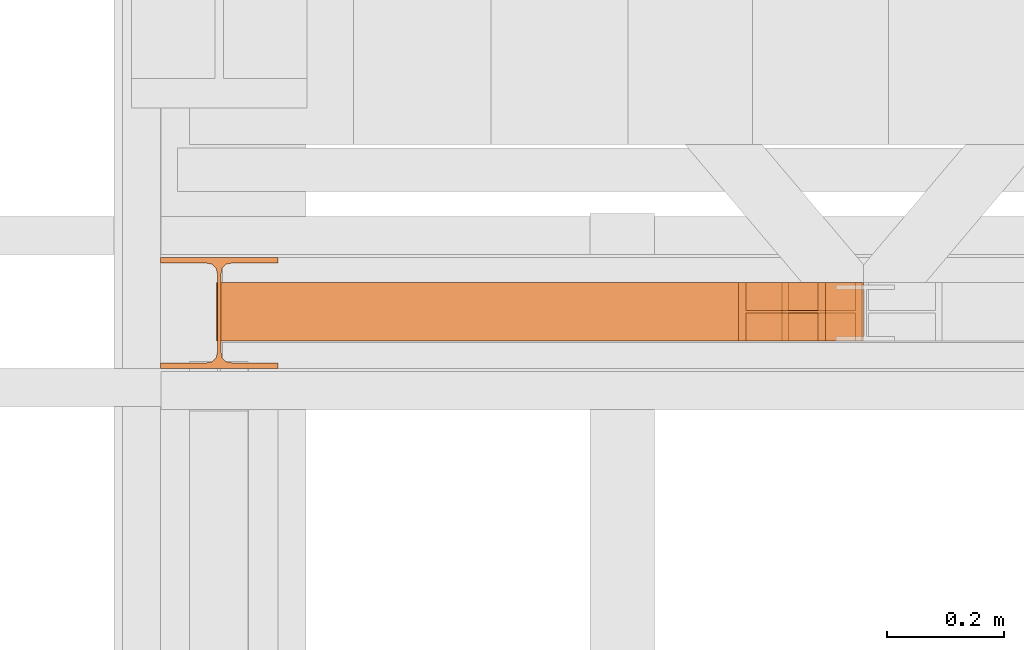
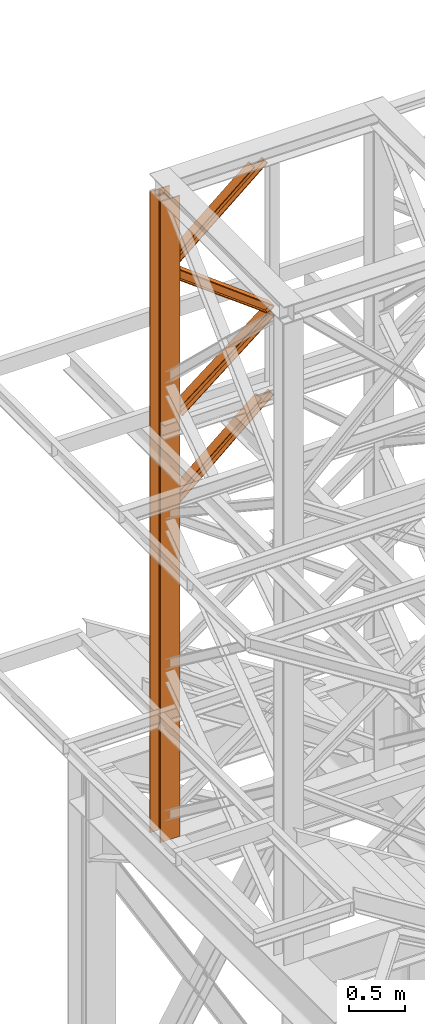
# One storey, part 97 of 208: 5 proxies.
"""IFC2X3 building model written with IfcOpenShell, lengths in millimetres."""

from ifc_helpers import new_model, entity, si_unit, converted_unit, frame, origin, origin_with_axes, place, context, subcontext, project, spatial, faceted_brep, element, save


model = new_model("IFC2X3")

# Units and contexts
model_context = context("Model", 3, precision=1e-05, world=origin())
plan_context = context("Plan", 3, precision=1e-05, world=origin())
body_context = subcontext(model_context, "Body", "Model", "MODEL_VIEW")
ifc_project = project(units=[si_unit("LENGTHUNIT", "METRE", prefix="MILLI"), converted_unit("PLANEANGLEUNIT", "DEGREE", entity("IfcPlaneAngleMeasure", 0.0174532925199433), si_unit("PLANEANGLEUNIT", "RADIAN"), dimensions=[0, 0, 0, 0, 0, 0, 0]), si_unit("AREAUNIT", "SQUARE_METRE"), si_unit("VOLUMEUNIT", "CUBIC_METRE")], contexts=[model_context, plan_context])

# Building, storey
building_placement = place(None, origin())
building = spatial("IfcBuilding", under=ifc_project, at=building_placement, CompositionType="COMPLEX")
storey_placement = place(building_placement, origin_with_axes())
storey = spatial("IfcBuildingStorey", under=building, at=storey_placement, Name="Geschoss", CompositionType="ELEMENT")

# Proxies
proxy_1_placement = place(storey_placement, frame((-3406.745032961453, -13857.57439657637, 5284.990005364415), z_axis=(0.0, 0.0, 1.0), x_axis=(1.0, 0.0, 0.0)))
element("IfcBuildingElementProxy", 1, at=proxy_1_placement, inside=storey, context=body_context, shape_type="Brep", body=[
    faceted_brep([(0.01000000000021828, 190.0100125169756, 6965.010053329393), (200.0100029802325, 190.0100125169756, 6965.010053329393), (200.0100029802325, 180.0100146031382, 6965.010053329393), (121.2600035762789, 180.0100071525576, 6965.010053329393), (111.9441915473344, 178.1454621052744, 6965.010053329393), (105.1245498640838, 171.3258190250399, 6965.010053329393), (103.2600015571716, 162.010007927418, 6965.010053329393), (103.2600015571716, 28.00999713897727, 6965.010053329393), (105.1245498640838, 18.69418604135535, 6965.010053329393), (111.9441915473344, 11.87454296112082, 6965.010053329393), (121.2600035762789, 10.00999791383765, 6965.010053329393), (200.0100029802325, 10.00999791383765, 6965.010053329393), (200.0100029802325, 0.01000000000021828, 6965.010053329393), (0.01000000000021828, 0.01000000000021828, 6965.010053329393), (0.01000000000021828, 10.00999791383765, 6965.010053329393), (78.75999940395377, 10.00999791383765, 6965.010053329393), (88.07581143289826, 11.87454296112082, 6965.010053329393), (94.89545311614893, 18.69418604135535, 6965.010053329393), (96.76000142306111, 28.00999713897727, 6965.010053329393), (96.76000142306111, 162.010007927418, 6965.010053329393), (94.89545311614893, 171.3258190250399, 6965.010053329393), (88.07581143289826, 178.1454621052744, 6965.010053329393), (78.75999940395377, 180.0100071525576, 6965.010053329393), (0.01000000000021828, 180.0100146031382, 6965.010053329393), (200.0100029802325, 190.0100125169756, 6965.010053329393), (0.01000000000021828, 190.0100125169756, 6965.010053329393), (0.01000000000203727, 190.0100125169756, 0.01000000000112777), (200.0100029802343, 190.0100125169756, 0.01000000000112777), (200.0100029802325, 180.0100146031382, 6965.010053329393), (200.0100029802325, 190.0100125169756, 6965.010053329393), (200.0100029802343, 190.0100125169756, 0.01000000000112777), (200.0100029802343, 180.0100146031382, 0.01000000000112777), (121.2600035762789, 180.0100071525576, 6965.010053329393), (200.0100029802325, 180.0100146031382, 6965.010053329393), (200.0100029802343, 180.0100146031382, 0.01000000000112777), (121.2600035762807, 180.0100071525576, 0.01000000000112777), (111.9441915473344, 178.1454621052744, 6965.010053329393), (121.2600035762789, 180.0100071525576, 6965.010053329393), (121.2600035762807, 180.0100071525576, 0.01000000000112777), (111.9441915473362, 178.1454621052744, 0.01000000000112777), (105.1245498640838, 171.3258190250399, 6965.010053329393), (111.9441915473344, 178.1454621052744, 6965.010053329393), (111.9441915473362, 178.1454621052744, 0.01000000000112777), (105.1245498640856, 171.3258190250399, 0.01000000000112777), (103.2600015571716, 162.010007927418, 6965.010053329393), (105.1245498640838, 171.3258190250399, 6965.010053329393), (105.1245498640856, 171.3258190250399, 0.01000000000112777), (103.2600015571734, 162.010007927418, 0.01000000000112777), (103.2600015571716, 28.00999713897727, 6965.010053329393), (103.2600015571716, 162.010007927418, 6965.010053329393), (103.2600015571734, 162.010007927418, 0.01000000000112777), (103.2600015571734, 28.00999713897727, 0.01000000000112777), (105.1245498640838, 18.69418604135535, 6965.010053329393), (103.2600015571716, 28.00999713897727, 6965.010053329393), (103.2600015571734, 28.00999713897727, 0.01000000000112777), (105.1245498640856, 18.69418604135535, 0.01000000000112777), (111.9441915473344, 11.87454296112082, 6965.010053329393), (105.1245498640838, 18.69418604135535, 6965.010053329393), (105.1245498640856, 18.69418604135535, 0.01000000000112777), (111.9441915473362, 11.87454296112082, 0.01000000000112777), (121.2600035762789, 10.00999791383765, 6965.010053329393), (111.9441915473344, 11.87454296112082, 6965.010053329393), (111.9441915473362, 11.87454296112082, 0.01000000000112777), (121.2600035762807, 10.00999791383765, 0.01000000000112777), (200.0100029802325, 10.00999791383765, 6965.010053329393), (121.2600035762789, 10.00999791383765, 6965.010053329393), (121.2600035762807, 10.00999791383765, 0.01000000000112777), (200.0100029802343, 10.00999791383765, 0.01000000000112777), (200.0100029802325, 0.01000000000021828, 6965.010053329393), (200.0100029802325, 10.00999791383765, 6965.010053329393), (200.0100029802343, 10.00999791383765, 0.01000000000112777), (200.0100029802343, 0.01000000000021828, 0.01000000000112777), (0.01000000000021828, 0.01000000000021828, 6965.010053329393), (200.0100029802325, 0.01000000000021828, 6965.010053329393), (200.0100029802343, 0.01000000000021828, 0.01000000000112777), (0.01000000000203727, 0.01000000000021828, 0.01000000000112777), (0.01000000000021828, 10.00999791383765, 6965.010053329393), (0.01000000000021828, 0.01000000000021828, 6965.010053329393), (0.01000000000203727, 0.01000000000021828, 0.01000000000112777), (0.01000000000203727, 10.00999791383765, 0.01000000000112777), (78.75999940395377, 10.00999791383765, 6965.010053329393), (0.01000000000021828, 10.00999791383765, 6965.010053329393), (0.01000000000203727, 10.00999791383765, 0.01000000000112777), (78.75999940395559, 10.00999791383765, 0.01000000000112777), (88.07581143289826, 11.87454296112082, 6965.010053329393), (78.75999940395377, 10.00999791383765, 6965.010053329393), (78.75999940395559, 10.00999791383765, 0.01000000000112777), (88.07581143290008, 11.87454296112082, 0.01000000000112777), (94.89545311614893, 18.69418604135535, 6965.010053329393), (88.07581143289826, 11.87454296112082, 6965.010053329393), (88.07581143290008, 11.87454296112082, 0.01000000000112777), (94.89545311615075, 18.69418604135535, 0.01000000000112777), (96.76000142306111, 28.00999713897727, 6965.010053329393), (94.89545311614893, 18.69418604135535, 6965.010053329393), (94.89545311615075, 18.69418604135535, 0.01000000000112777), (96.76000142306293, 28.00999713897727, 0.01000000000112777), (96.76000142306111, 162.010007927418, 6965.010053329393), (96.76000142306111, 28.00999713897727, 6965.010053329393), (96.76000142306293, 28.00999713897727, 0.01000000000112777), (96.76000142306293, 162.010007927418, 0.01000000000112777), (94.89545311614893, 171.3258190250399, 6965.010053329393), (96.76000142306111, 162.010007927418, 6965.010053329393), (96.76000142306293, 162.010007927418, 0.01000000000112777), (94.89545311615075, 171.3258190250399, 0.01000000000112777), (88.07581143289826, 178.1454621052744, 6965.010053329393), (94.89545311614893, 171.3258190250399, 6965.010053329393), (94.89545311615075, 171.3258190250399, 0.01000000000112777), (88.07581143290008, 178.1454621052744, 0.01000000000112777), (78.75999940395377, 180.0100071525576, 6965.010053329393), (88.07581143289826, 178.1454621052744, 6965.010053329393), (88.07581143290008, 178.1454621052744, 0.01000000000112777), (78.75999940395559, 180.0100071525576, 0.01000000000112777), (0.01000000000021828, 180.0100146031382, 6965.010053329393), (78.75999940395377, 180.0100071525576, 6965.010053329393), (78.75999940395559, 180.0100071525576, 0.01000000000112777), (0.01000000000203727, 180.0100146031382, 0.01000000000112777), (0.01000000000021828, 190.0100125169756, 6965.010053329393), (0.01000000000021828, 180.0100146031382, 6965.010053329393), (0.01000000000203727, 180.0100146031382, 0.01000000000112777), (0.01000000000203727, 190.0100125169756, 0.01000000000112777), (0.01000000000203727, 190.0100125169756, 0.01000000000112777), (0.01000000000203727, 180.0100146031382, 0.01000000000112777), (78.75999940395559, 180.0100071525576, 0.01000000000112777), (88.07581143290008, 178.1454621052744, 0.01000000000112777), (94.89545311615075, 171.3258190250399, 0.01000000000112777), (96.76000142306293, 162.010007927418, 0.01000000000112777), (96.76000142306293, 28.00999713897727, 0.01000000000112777), (94.89545311615075, 18.69418604135535, 0.01000000000112777), (88.07581143290008, 11.87454296112082, 0.01000000000112777), (78.75999940395559, 10.00999791383765, 0.01000000000112777), (0.01000000000203727, 10.00999791383765, 0.01000000000112777), (0.01000000000203727, 0.01000000000021828, 0.01000000000112777), (200.0100029802343, 0.01000000000021828, 0.01000000000112777), (200.0100029802343, 10.00999791383765, 0.01000000000112777), (121.2600035762807, 10.00999791383765, 0.01000000000112777), (111.9441915473362, 11.87454296112082, 0.01000000000112777), (105.1245498640856, 18.69418604135535, 0.01000000000112777), (103.2600015571734, 28.00999713897727, 0.01000000000112777), (103.2600015571734, 162.010007927418, 0.01000000000112777), (105.1245498640856, 171.3258190250399, 0.01000000000112777), (111.9441915473362, 178.1454621052744, 0.01000000000112777), (121.2600035762807, 180.0100071525576, 0.01000000000112777), (200.0100029802343, 180.0100146031382, 0.01000000000112777), (200.0100029802343, 190.0100125169756, 0.01000000000112777)], [[[0, 1, 2, 3, 4, 5, 6, 7, 8, 9, 10, 11, 12, 13, 14, 15, 16, 17, 18, 19, 20, 21, 22, 23]], [[24, 25, 26, 27]], [[28, 29, 30, 31]], [[32, 33, 34, 35]], [[36, 37, 38, 39]], [[40, 41, 42, 43]], [[44, 45, 46, 47]], [[48, 49, 50, 51]], [[52, 53, 54, 55]], [[56, 57, 58, 59]], [[60, 61, 62, 63]], [[64, 65, 66, 67]], [[68, 69, 70, 71]], [[72, 73, 74, 75]], [[76, 77, 78, 79]], [[80, 81, 82, 83]], [[84, 85, 86, 87]], [[88, 89, 90, 91]], [[92, 93, 94, 95]], [[96, 97, 98, 99]], [[100, 101, 102, 103]], [[104, 105, 106, 107]], [[108, 109, 110, 111]], [[112, 113, 114, 115]], [[116, 117, 118, 119]], [[120, 121, 122, 123, 124, 125, 126, 127, 128, 129, 130, 131, 132, 133, 134, 135, 136, 137, 138, 139, 140, 141, 142, 143]]], orient=[[False], [False], [False], [False], [False], [False], [False], [False], [False], [False], [False], [False], [False], [False], [False], [False], [False], [False], [False], [False], [False], [False], [False], [False], [False], [False]]),
])
proxy_2_placement = place(storey_placement, frame((-3304.352981117381, -13810.57439404318, 11377.72088058774), z_axis=(0.0, 0.0, 1.0), x_axis=(1.0, 0.0, 0.0)))
element("IfcBuildingElementProxy", 2, at=proxy_2_placement, inside=storey, context=body_context, shape_type="Brep", body=[
    faceted_brep([(0.05739452718080429, 0.01000000000021828, 114.8626276162686), (0.06170312055837712, 0.01000000000021828, 125.3037755813875), (884.1142223632123, 0.01000000000203727, 872.3672389455751), (896.4596268830774, 0.01000000000203727, 872.362144550938), (0.06170312055837712, 0.01000000000021828, 125.3037755813875), (0.0617031205620151, 100.0100000000002, 125.3037755813875), (884.1142223632123, 100.010000000002, 872.3672389455751), (884.1142223632123, 0.01000000000203727, 872.3672389455751), (0.0617031205620151, 100.0100000000002, 125.3037755813875), (0.05739452718080429, 100.0100000000002, 114.8626276162686), (896.4596268830792, 100.010000000002, 872.362144550938), (884.1142223632123, 100.010000000002, 872.3672389455751), (0.05739452718080429, 100.0100000000002, 114.8626276162686), (0.05739452718080429, 52.51000000000022, 114.8626276162704), (896.4596268830755, 52.51000000000204, 872.362144550938), (896.4596268830792, 100.010000000002, 872.362144550938), (0.05739452718080429, 52.51000000000022, 114.8626276162704), (0.0143085933796101, 52.51000000000022, 10.45114796511371), (1019.913672081704, 52.51000000000204, 872.3112006045758), (896.4596268830755, 52.51000000000204, 872.362144550938), (0.0143085933796101, 52.51000000000022, 10.45114796511371), (0.0143085933796101, 100.0100000000002, 10.45114796511371), (1019.913672081704, 100.010000000002, 872.311200604574), (1019.913672081704, 52.51000000000204, 872.3112006045758), (0.0143085933796101, 100.0100000000002, 10.45114796511371), (0.01000000000021828, 100.0100000000002, 0.01000000000021828), (1032.259076601566, 100.010000000002, 872.3061062099387), (1019.913672081704, 100.010000000002, 872.311200604574), (0.01000000000021828, 100.0100000000002, 0.01000000000021828), (0.01000000000021828, 0.01000000000021828, 0.01000000000021828), (1032.259076601567, 0.01000000000203727, 872.3061062099387), (1032.259076601566, 100.010000000002, 872.3061062099387), (0.01000000000021828, 0.01000000000021828, 0.01000000000021828), (0.0143085933796101, 0.01000000000021828, 10.45114796511371), (1019.913672081704, 0.01000000000203727, 872.3112006045758), (1032.259076601567, 0.01000000000203727, 872.3061062099387), (0.0143085933796101, 0.01000000000021828, 10.45114796511371), (0.0143085933796101, 47.51000000000022, 10.45114796511371), (1019.913672081704, 47.51000000000204, 872.311200604574), (1019.913672081704, 0.01000000000203727, 872.3112006045758), (0.0143085933796101, 47.51000000000022, 10.45114796511371), (0.05739452718080429, 47.51000000000022, 114.8626276162686), (896.4596268830774, 47.51000000000204, 872.362144550938), (1019.913672081704, 47.51000000000204, 872.311200604574), (0.05739452718080429, 47.51000000000022, 114.8626276162686), (0.05739452718080429, 0.01000000000021828, 114.8626276162686), (896.4596268830774, 0.01000000000203727, 872.362144550938), (896.4596268830774, 47.51000000000204, 872.362144550938), (896.4596268830774, 0.01000000000203727, 872.362144550938), (884.1142223632123, 0.01000000000203727, 872.3672389455751), (884.1142223632123, 100.010000000002, 872.3672389455751), (896.4596268830792, 100.010000000002, 872.362144550938), (896.4596268830755, 52.51000000000204, 872.362144550938), (1019.913672081704, 52.51000000000204, 872.3112006045758), (1019.913672081704, 100.010000000002, 872.311200604574), (1032.259076601566, 100.010000000002, 872.3061062099387), (1032.259076601567, 0.01000000000203727, 872.3061062099387), (1019.913672081704, 0.01000000000203727, 872.3112006045758), (1019.913672081704, 47.51000000000204, 872.311200604574), (896.4596268830774, 47.51000000000204, 872.362144550938), (0.06170312055837712, 0.01000000000021828, 125.3037755813875), (0.05739452718080429, 0.01000000000021828, 114.8626276162686), (0.05739452718080429, 47.51000000000022, 114.8626276162686), (0.0143085933796101, 47.51000000000022, 10.45114796511371), (0.0143085933796101, 0.01000000000021828, 10.45114796511371), (0.01000000000021828, 0.01000000000021828, 0.01000000000021828), (0.01000000000021828, 100.0100000000002, 0.01000000000021828), (0.0143085933796101, 100.0100000000002, 10.45114796511371), (0.0143085933796101, 52.51000000000022, 10.45114796511371), (0.05739452718080429, 52.51000000000022, 114.8626276162704), (0.05739452718080429, 100.0100000000002, 114.8626276162686), (0.0617031205620151, 100.0100000000002, 125.3037755813875)], [[[0, 1, 2, 3]], [[4, 5, 6, 7]], [[8, 9, 10, 11]], [[12, 13, 14, 15]], [[16, 17, 18, 19]], [[20, 21, 22, 23]], [[24, 25, 26, 27]], [[28, 29, 30, 31]], [[32, 33, 34, 35]], [[36, 37, 38, 39]], [[40, 41, 42, 43]], [[44, 45, 46, 47]], [[48, 49, 50, 51, 52, 53, 54, 55, 56, 57, 58, 59]], [[60, 61, 62, 63, 64, 65, 66, 67, 68, 69, 70, 71]]], orient=[[False], [False], [False], [False], [False], [False], [False], [False], [False], [False], [False], [False], [False], [False]]),
])
proxy_3_placement = place(storey_placement, frame((-3304.352805793071, -13810.57439404318, 10561.56098086555), z_axis=(0.0, 0.0, 1.0), x_axis=(1.0, 0.0, 0.0)))
element("IfcBuildingElementProxy", 3, at=proxy_3_placement, inside=storey, context=body_context, shape_type="Brep", body=[
    faceted_brep([(0.01430859338324808, 0.01000000000021828, 827.0359165370173), (1097.168147875129, 0.01000000000203727, 9.251571989843796), (1097.16433429294, 0.01000000000203727, 0.01000000000203727), (0.01000000000021828, 0.01000000000021828, 816.5947685719002), (0.01000000000021828, 0.01000000000021828, 816.5947685719002), (1097.16433429294, 0.01000000000203727, 0.01000000000203727), (1097.164334292942, 100.010000000002, 0.01000000000021828), (0.01000000000385626, 100.0100000000002, 816.5947685719002), (0.01000000000385626, 100.0100000000002, 816.5947685719002), (1097.164334292942, 100.010000000002, 0.01000000000021828), (1097.168147875127, 100.010000000002, 9.251571989843796), (0.01430859338324808, 100.0100000000002, 827.0359165370173), (0.01430859338324808, 100.0100000000002, 827.0359165370173), (1097.168147875127, 100.010000000002, 9.251571989843796), (1097.168147875127, 52.51000000000204, 9.251571989841977), (0.01430859338506707, 52.51000000000022, 827.0359165370155), (0.01430859338506707, 52.51000000000022, 827.0359165370155), (1097.168147875127, 52.51000000000204, 9.251571989841977), (1097.206810165455, 52.51000000000204, 102.9430992163325), (0.05739452718626126, 52.51000000000022, 931.4473961881722), (0.05739452718626126, 52.51000000000022, 931.4473961881722), (1097.206810165455, 52.51000000000204, 102.9430992163325), (1097.206810165457, 100.010000000002, 102.9430992163325), (0.05739452718626126, 100.0100000000002, 931.4473961881722), (0.05739452718626126, 100.0100000000002, 931.4473961881722), (1097.206810165457, 100.010000000002, 102.9430992163325), (1097.210722991558, 100.010000000002, 112.4251720589109), (0.06170312056565308, 100.0100000000002, 941.8885441532875), (0.06170312056565308, 100.0100000000002, 941.8885441532875), (1097.210722991558, 100.010000000002, 112.4251720589109), (1097.210722991556, 0.01000000000203727, 112.4251720589127), (0.06170312056565308, 0.01000000000021828, 941.8885441532875), (0.06170312056565308, 0.01000000000021828, 941.8885441532875), (1097.210722991556, 0.01000000000203727, 112.4251720589127), (1097.206810165455, 0.01000000000203727, 102.9430992163325), (0.05739452718626126, 0.01000000000021828, 931.4473961881722), (0.05739452718626126, 0.01000000000021828, 931.4473961881722), (1097.206810165455, 0.01000000000203727, 102.9430992163325), (1097.206810165455, 47.51000000000204, 102.9430992163343), (0.05739452718626126, 47.51000000000022, 931.4473961881722), (0.05739452718626126, 47.51000000000022, 931.4473961881722), (1097.206810165455, 47.51000000000204, 102.9430992163343), (1097.168147875129, 47.51000000000204, 9.251571989841977), (0.01430859338506707, 47.51000000000022, 827.0359165370173), (0.01430859338506707, 47.51000000000022, 827.0359165370173), (1097.168147875129, 47.51000000000204, 9.251571989841977), (1097.168147875129, 0.01000000000203727, 9.251571989843796), (0.01430859338324808, 0.01000000000021828, 827.0359165370173), (0.01000000000021828, 0.01000000000021828, 816.5947685719002), (0.01000000000385626, 100.0100000000002, 816.5947685719002), (0.01430859338324808, 100.0100000000002, 827.0359165370173), (0.01430859338506707, 52.51000000000022, 827.0359165370155), (0.05739452718626126, 52.51000000000022, 931.4473961881722), (0.05739452718626126, 100.0100000000002, 931.4473961881722), (0.06170312056565308, 100.0100000000002, 941.8885441532875), (0.06170312056565308, 0.01000000000021828, 941.8885441532875), (0.05739452718626126, 0.01000000000021828, 931.4473961881722), (0.05739452718626126, 47.51000000000022, 931.4473961881722), (0.01430859338506707, 47.51000000000022, 827.0359165370173), (0.01430859338324808, 0.01000000000021828, 827.0359165370173), (1097.16433429294, 0.01000000000203727, 0.01000000000203727), (1097.168147875129, 0.01000000000203727, 9.251571989843796), (1097.168147875129, 47.51000000000204, 9.251571989841977), (1097.206810165455, 47.51000000000204, 102.9430992163343), (1097.206810165455, 0.01000000000203727, 102.9430992163325), (1097.210722991556, 0.01000000000203727, 112.4251720589127), (1097.210722991558, 100.010000000002, 112.4251720589109), (1097.206810165457, 100.010000000002, 102.9430992163325), (1097.206810165455, 52.51000000000204, 102.9430992163325), (1097.168147875127, 52.51000000000204, 9.251571989841977), (1097.168147875127, 100.010000000002, 9.251571989843796), (1097.164334292942, 100.010000000002, 0.01000000000021828)], [[[0, 1, 2, 3]], [[4, 5, 6, 7]], [[8, 9, 10, 11]], [[12, 13, 14, 15]], [[16, 17, 18, 19]], [[20, 21, 22, 23]], [[24, 25, 26, 27]], [[28, 29, 30, 31]], [[32, 33, 34, 35]], [[36, 37, 38, 39]], [[40, 41, 42, 43]], [[44, 45, 46, 47]], [[48, 49, 50, 51, 52, 53, 54, 55, 56, 57, 58, 59]], [[60, 61, 62, 63, 64, 65, 66, 67, 68, 69, 70, 71]]], orient=[[False], [False], [False], [False], [False], [False], [False], [False], [False], [False], [False], [False], [False], [False]]),
])
proxy_4_placement = place(storey_placement, frame((-3311.209746515184, -13810.57439404318, 9806.493929602915), z_axis=(0.0, 0.0, 1.0), x_axis=(1.0, 0.0, 0.0)))
element("IfcBuildingElementProxy", 4, at=proxy_4_placement, inside=storey, context=body_context, shape_type="Brep", body=[
    faceted_brep([(0.01000000000021828, 0.01000000000021828, 0.07729601297614863), (1104.067663713673, 0.01000000000021828, 867.4922233215475), (1104.063668153769, 0.01000000000021828, 857.8096590872556), (9.433376635164677, 0.01000000000021828, 0.07340740816653124), (0.01000000000021828, 100.0100000000002, 0.07729601297614863), (1104.067663713673, 100.0100000000002, 867.4922233215493), (1104.067663713673, 0.01000000000021828, 867.4922233215475), (0.01000000000021828, 0.01000000000021828, 0.07729601297614863), (9.433376635164677, 100.0100000000002, 0.07340740816653124), (1104.063668153769, 100.0100000000002, 857.8096590872556), (1104.067663713673, 100.0100000000002, 867.4922233215493), (0.01000000000021828, 100.0100000000002, 0.07729601297614863), (9.433376635164677, 52.51000000000022, 0.07340740816653124), (1104.063668153769, 52.51000000000022, 857.8096590872556), (1104.063668153769, 100.0100000000002, 857.8096590872556), (9.433376635164677, 100.0100000000002, 0.07340740816653124), (153.6671387297192, 52.51000000000022, 0.01388860480983567), (1104.023712554726, 52.51000000000022, 760.984016744329), (1104.063668153769, 52.51000000000022, 857.8096590872556), (9.433376635164677, 52.51000000000022, 0.07340740816653124), (153.6671387297156, 100.0100000000002, 0.01388860480983567), (1104.023712554726, 100.0100000000002, 760.984016744329), (1104.023712554726, 52.51000000000022, 760.984016744329), (153.6671387297192, 52.51000000000022, 0.01388860480983567), (163.0905153648837, 100.0100000000002, 0.01000000000021828), (1104.019716994822, 100.0100000000002, 751.301452510037), (1104.023712554726, 100.0100000000002, 760.984016744329), (153.6671387297156, 100.0100000000002, 0.01388860480983567), (163.0905153648873, 0.01000000000021828, 0.01000000000021828), (1104.019716994822, 0.01000000000021828, 751.301452510037), (1104.019716994822, 100.0100000000002, 751.301452510037), (163.0905153648837, 100.0100000000002, 0.01000000000021828), (153.6671387297156, 0.01000000000021828, 0.01388860480983567), (1104.023712554726, 0.01000000000021828, 760.984016744329), (1104.019716994822, 0.01000000000021828, 751.301452510037), (163.0905153648873, 0.01000000000021828, 0.01000000000021828), (153.6671387297156, 47.51000000000022, 0.01388860481165466), (1104.023712554726, 47.51000000000022, 760.984016744329), (1104.023712554726, 0.01000000000021828, 760.984016744329), (153.6671387297156, 0.01000000000021828, 0.01388860480983567), (9.433376635164677, 47.51000000000022, 0.07340740816653124), (1104.063668153769, 47.51000000000022, 857.8096590872556), (1104.023712554726, 47.51000000000022, 760.984016744329), (153.6671387297156, 47.51000000000022, 0.01388860481165466), (9.433376635164677, 0.01000000000021828, 0.07340740816653124), (1104.063668153769, 0.01000000000021828, 857.8096590872556), (1104.063668153769, 47.51000000000022, 857.8096590872556), (9.433376635164677, 47.51000000000022, 0.07340740816653124), (1104.067663713673, 0.01000000000021828, 867.4922233215475), (1104.067663713673, 100.0100000000002, 867.4922233215493), (1104.063668153769, 100.0100000000002, 857.8096590872556), (1104.063668153769, 52.51000000000022, 857.8096590872556), (1104.023712554726, 52.51000000000022, 760.984016744329), (1104.023712554726, 100.0100000000002, 760.984016744329), (1104.019716994822, 100.0100000000002, 751.301452510037), (1104.019716994822, 0.01000000000021828, 751.301452510037), (1104.023712554726, 0.01000000000021828, 760.984016744329), (1104.023712554726, 47.51000000000022, 760.984016744329), (1104.063668153769, 47.51000000000022, 857.8096590872556), (1104.063668153769, 0.01000000000021828, 857.8096590872556), (9.433376635164677, 0.01000000000021828, 0.07340740816653124), (9.433376635164677, 47.51000000000022, 0.07340740816653124), (153.6671387297156, 47.51000000000022, 0.01388860481165466), (153.6671387297156, 0.01000000000021828, 0.01388860480983567), (163.0905153648873, 0.01000000000021828, 0.01000000000021828), (163.0905153648837, 100.0100000000002, 0.01000000000021828), (153.6671387297156, 100.0100000000002, 0.01388860480983567), (153.6671387297192, 52.51000000000022, 0.01388860480983567), (9.433376635164677, 52.51000000000022, 0.07340740816653124), (9.433376635164677, 100.0100000000002, 0.07340740816653124), (0.01000000000021828, 100.0100000000002, 0.07729601297614863), (0.01000000000021828, 0.01000000000021828, 0.07729601297614863)], [[[0, 1, 2, 3]], [[4, 5, 6, 7]], [[8, 9, 10, 11]], [[12, 13, 14, 15]], [[16, 17, 18, 19]], [[20, 21, 22, 23]], [[24, 25, 26, 27]], [[28, 29, 30, 31]], [[32, 33, 34, 35]], [[36, 37, 38, 39]], [[40, 41, 42, 43]], [[44, 45, 46, 47]], [[48, 49, 50, 51, 52, 53, 54, 55, 56, 57, 58, 59]], [[60, 61, 62, 63, 64, 65, 66, 67, 68, 69, 70, 71]]], orient=[[False], [False], [False], [False], [False], [False], [False], [False], [False], [False], [False], [False], [False], [False]]),
])
proxy_5_placement = place(storey_placement, frame((-3305.14184141053, -13810.57439404318, 8759.450598597716), z_axis=(0.0, 0.0, 1.0), x_axis=(1.0, 0.0, 0.0)))
element("IfcBuildingElementProxy", 5, at=proxy_5_placement, inside=storey, context=body_context, shape_type="Brep", body=[
    faceted_brep([(0.06273209084611153, 0.01000000000021828, 127.7973111790107), (0.06618405386689119, 0.01000000000021828, 136.1625602273107), (958.7383043471636, 0.01000000000021828, 950.7224907291948), (969.946944568861, 0.01000000000021828, 950.7178654261916), (0.06618405386689119, 0.01000000000021828, 136.1625602273107), (0.06618405386689119, 100.0100000000002, 136.1625602273107), (958.7383043471636, 100.0100000000002, 950.7224907291948), (958.7383043471636, 0.01000000000021828, 950.7224907291948), (0.06618405386689119, 100.0100000000002, 136.1625602273107), (0.06273209084611153, 100.0100000000002, 127.7973111790107), (969.946944568861, 100.0100000000002, 950.7178654261916), (958.7383043471636, 100.0100000000002, 950.7224907291948), (0.06273209084611153, 100.0100000000002, 127.7973111790107), (0.06273209084611153, 52.51000000000022, 127.7973111790107), (969.946944568861, 52.51000000000022, 950.7178654261897), (969.946944568861, 100.0100000000002, 950.7178654261916), (0.06273209084611153, 52.51000000000022, 127.7973111790107), (0.01345133434369927, 52.51000000000022, 8.373725554703924), (1084.239602132224, 52.51000000000022, 950.6707019735295), (969.946944568861, 52.51000000000022, 950.7178654261897), (0.01345133434369927, 52.51000000000022, 8.373725554703924), (0.01345133434369927, 100.0100000000002, 8.373725554707562), (1084.239602132224, 100.0100000000002, 950.6707019735295), (1084.239602132224, 52.51000000000022, 950.6707019735295), (0.01345133434369927, 100.0100000000002, 8.373725554707562), (0.01000000000021828, 100.0100000000002, 0.01000000000203727), (1095.371277356315, 100.0100000000002, 950.6661084305288), (1084.239602132224, 100.0100000000002, 950.6707019735295), (0.01000000000021828, 100.0100000000002, 0.01000000000203727), (0.01000000000021828, 0.01000000000021828, 0.01000000000021828), (1095.371277356315, 0.01000000000021828, 950.6661084305288), (1095.371277356315, 100.0100000000002, 950.6661084305288), (0.01000000000021828, 0.01000000000021828, 0.01000000000021828), (0.01345133434369927, 0.01000000000021828, 8.373725554707562), (1084.239602132224, 0.01000000000021828, 950.6707019735295), (1095.371277356315, 0.01000000000021828, 950.6661084305288), (0.01345133434369927, 0.01000000000021828, 8.373725554707562), (0.01345133434369927, 47.51000000000022, 8.3737255547112), (1084.239602132222, 47.51000000000022, 950.6707019735295), (1084.239602132224, 0.01000000000021828, 950.6707019735295), (0.01345133434369927, 47.51000000000022, 8.3737255547112), (0.06273209084611153, 47.51000000000022, 127.7973111790107), (969.946944568861, 47.51000000000022, 950.7178654261916), (1084.239602132222, 47.51000000000022, 950.6707019735295), (0.06273209084611153, 47.51000000000022, 127.7973111790107), (0.06273209084611153, 0.01000000000021828, 127.7973111790107), (969.946944568861, 0.01000000000021828, 950.7178654261916), (969.946944568861, 47.51000000000022, 950.7178654261916), (969.946944568861, 0.01000000000021828, 950.7178654261916), (958.7383043471636, 0.01000000000021828, 950.7224907291948), (958.7383043471636, 100.0100000000002, 950.7224907291948), (969.946944568861, 100.0100000000002, 950.7178654261916), (969.946944568861, 52.51000000000022, 950.7178654261897), (1084.239602132224, 52.51000000000022, 950.6707019735295), (1084.239602132224, 100.0100000000002, 950.6707019735295), (1095.371277356315, 100.0100000000002, 950.6661084305288), (1095.371277356315, 0.01000000000021828, 950.6661084305288), (1084.239602132224, 0.01000000000021828, 950.6707019735295), (1084.239602132222, 47.51000000000022, 950.6707019735295), (969.946944568861, 47.51000000000022, 950.7178654261916), (0.06618405386689119, 0.01000000000021828, 136.1625602273107), (0.06273209084611153, 0.01000000000021828, 127.7973111790107), (0.06273209084611153, 47.51000000000022, 127.7973111790107), (0.01345133434369927, 47.51000000000022, 8.3737255547112), (0.01345133434369927, 0.01000000000021828, 8.373725554707562), (0.01000000000021828, 0.01000000000021828, 0.01000000000021828), (0.01000000000021828, 100.0100000000002, 0.01000000000203727), (0.01345133434369927, 100.0100000000002, 8.373725554707562), (0.01345133434369927, 52.51000000000022, 8.373725554703924), (0.06273209084611153, 52.51000000000022, 127.7973111790107), (0.06273209084611153, 100.0100000000002, 127.7973111790107), (0.06618405386689119, 100.0100000000002, 136.1625602273107)], [[[0, 1, 2, 3]], [[4, 5, 6, 7]], [[8, 9, 10, 11]], [[12, 13, 14, 15]], [[16, 17, 18, 19]], [[20, 21, 22, 23]], [[24, 25, 26, 27]], [[28, 29, 30, 31]], [[32, 33, 34, 35]], [[36, 37, 38, 39]], [[40, 41, 42, 43]], [[44, 45, 46, 47]], [[48, 49, 50, 51, 52, 53, 54, 55, 56, 57, 58, 59]], [[60, 61, 62, 63, 64, 65, 66, 67, 68, 69, 70, 71]]], orient=[[False], [False], [False], [False], [False], [False], [False], [False], [False], [False], [False], [False], [False], [False]]),
])

save(model, "model.ifc")
